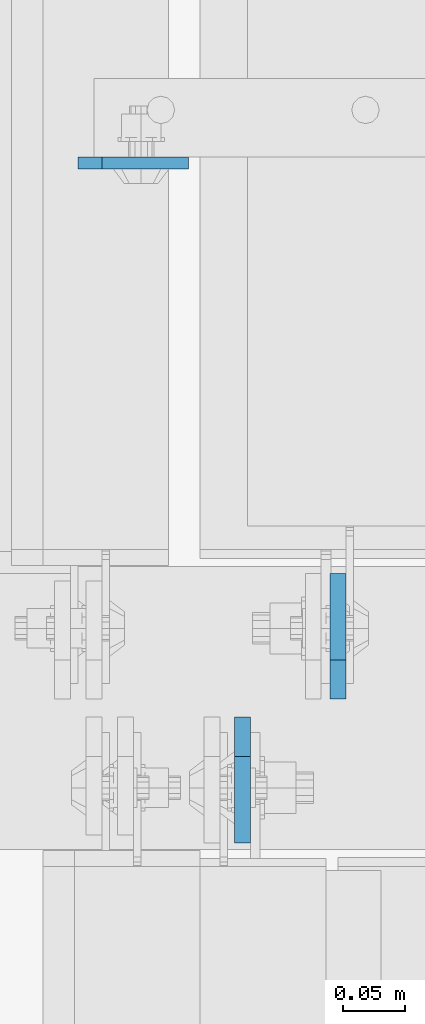
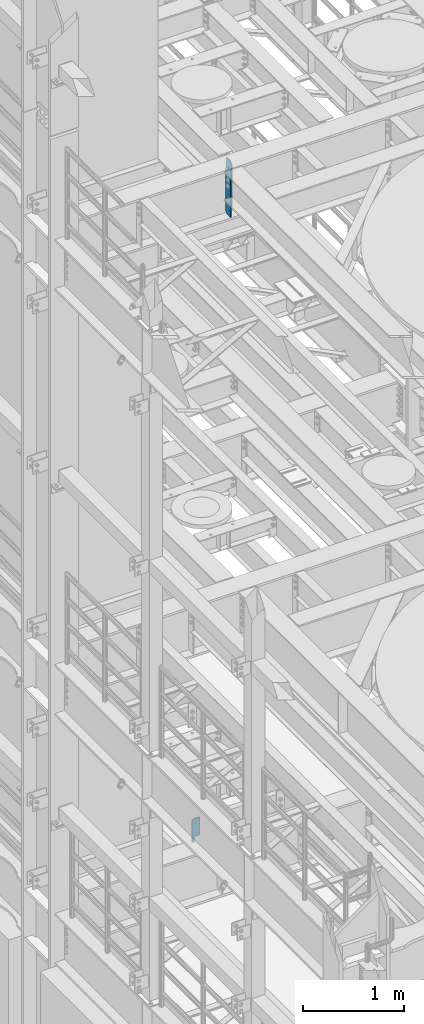
# One storey, part 1560 of 1876: 3 plates, 2 elements without a shape of their own.
"""IFC2X3 building model written with IfcOpenShell, lengths in millimetres."""

from ifc_helpers import new_model, si_unit, frame, origin_with_axes, place, context, subcontext, project, spatial, faceted_brep, material, type_object, element, aggregate, save


model = new_model("IFC2X3")

# Units and contexts
model_context = context("Model", 3, precision=1e-05, world=origin_with_axes())
body_context = subcontext(model_context, "Body", "Model", "MODEL_VIEW")
ifc_project = project(units=[si_unit("LENGTHUNIT", "METRE", prefix="MILLI"), si_unit("AREAUNIT", "SQUARE_METRE"), si_unit("VOLUMEUNIT", "CUBIC_METRE"), si_unit("MASSUNIT", "GRAM", prefix="KILO"), si_unit("TIMEUNIT", "SECOND"), si_unit("PLANEANGLEUNIT", "RADIAN"), si_unit("SOLIDANGLEUNIT", "STERADIAN"), si_unit("THERMODYNAMICTEMPERATUREUNIT", "DEGREE_CELSIUS"), si_unit("LUMINOUSINTENSITYUNIT", "LUMEN")], contexts=[model_context])

# Site, building, storey
site_placement = place(None, origin_with_axes())
site = spatial("IfcSite", under=ifc_project, at=site_placement, CompositionType="ELEMENT")
building_placement = place(site_placement, origin_with_axes())
building = spatial("IfcBuilding", under=site, at=building_placement, Name="Undefined", CompositionType="ELEMENT")
storey_placement = place(building_placement, origin_with_axes())
storey = spatial("IfcBuildingStorey", under=building, at=storey_placement, Name="Undefined", CompositionType="ELEMENT", Elevation=0.0)

# Assembly, plate
assembly_1_placement = place(storey_placement, origin_with_axes())
assembly_1 = element("IfcElementAssembly", 1, at=assembly_1_placement, inside=storey, Name="BEAM", AssemblyPlace="NOTDEFINED", PredefinedType="RIGID_FRAME")
ifc_material = material(Name="STEEL/A36")
plate_type_1 = type_object("IfcPlateType", PredefinedType="NOTDEFINED")
plate_1_placement = place(assembly_1_placement, frame((1882.775, 1963.73659114838, 4833.9375), z_axis=(0.0, 0.0, 1.0), x_axis=(1.0, 0.0, 0.0)))
plate_1 = element("IfcPlate", 2, at=plate_1_placement, type_object=plate_type_1, material=ifc_material, Name="PLATE", context=body_context, shape_type="Brep", body=[
    faceted_brep([(28.5737429031849, -4.76250000000005, 0.0), (28.5737429031849, 4.76250000000005, 0.0), (28.5737429031849, 4.76250000000005, 65.0875016212467), (28.5737429031849, -4.76250000000005, 65.0875016212467), (29.0571078644789, 4.76250000000005, 67.5175413802699), (29.0571078644789, -4.76250000000005, 67.5175413802699), (30.4336148147179, 4.76250000000005, 69.5776296143467), (30.4336148147179, -4.76250000000005, 69.5776296143467), (32.4937030487947, 4.76250000000005, 70.9541365645855), (32.4937030487947, -4.76250000000005, 70.9541365645855), (34.9237428078175, 4.76250000000005, 71.4375015258793), (34.9237428078175, -4.76250000000005, 71.4375015258793), (88.9000283049895, -4.76249999986135, 71.4375), (88.9000015258789, 4.76250000000005, 71.4375), (19.0499992370605, -4.76249999999982, 0.0), (0.0, -4.76249999999982, 19.0499992370605), (0.0, 4.76249999999982, 19.0499992370605), (19.0499992370605, 4.76249999999982, 0.0), (0.0, -4.76249999999982, 271.462512969971), (0.0, 4.76249999999982, 271.462512969971), (19.0499992370605, -4.76249999999982, 290.512512207031), (19.0499992370605, 4.76249999999982, 290.512512207031), (88.9000015258789, -4.76249999999982, 290.512512207031), (88.9000015258789, 4.76249999999982, 290.512512207031)], [[[0, 1, 2, 3]], [[3, 2, 4, 5]], [[5, 4, 6, 7]], [[7, 6, 8, 9]], [[9, 8, 10, 11]], [[12, 11, 10, 13]], [[14, 15, 16, 17]], [[15, 18, 19, 16]], [[18, 20, 21, 19]], [[20, 22, 23, 21]], [[23, 22, 12, 13]], [[8, 6, 4, 2, 1, 17, 16, 19, 21, 23, 13, 10]], [[14, 17, 1, 0]], [[22, 20, 18, 15, 14, 0, 3, 5, 7, 9, 11, 12]]]),
])
aggregate(assembly_1, [plate_1])

# Assembly, plates
assembly_2_placement = place(storey_placement, origin_with_axes())
assembly_2 = element("IfcElementAssembly", 3, at=assembly_2_placement, inside=storey, Name="BEAM", AssemblyPlace="NOTDEFINED", PredefinedType="RIGID_FRAME")
plate_type_2 = type_object("IfcPlateType", PredefinedType="NOTDEFINED")
plate_2_placement = place(assembly_2_placement, frame((2092.32499990463, 1531.14375, 12714.2875), z_axis=(0.0, 0.0, 1.0), x_axis=(0.0, 1.0, 0.0)))
plate_2 = element("IfcPlate", 4, at=plate_2_placement, type_object=plate_type_2, material=ifc_material, Name="PLATE", context=body_context, shape_type="Brep", body=[
    faceted_brep([(0.0, -6.34999999999991, 31.75), (0.0, -6.35000000000036, 538.162475585938), (0.0, 6.35000000000036, 538.162475585938), (0.0, 6.34999999999991, 31.75), (31.75, -6.35000000000036, 569.912475585938), (31.75, 6.35000000000036, 569.912475585938), (101.599998474121, -6.34999999999991, 569.912475585938), (101.599998474121, 6.34999999999991, 569.912475585938), (101.599998474121, -6.35000000000036, 0.0), (101.599998474121, 6.35000000000036, 0.0), (31.75, -6.34999999999991, 0.0), (31.75, 6.34999999999991, 0.0)], [[[0, 1, 2, 3]], [[1, 4, 5, 2]], [[4, 6, 7, 5]], [[6, 8, 9, 7]], [[8, 10, 11, 9]], [[10, 0, 3, 11]], [[5, 7, 9, 11, 3, 2]], [[10, 8, 6, 4, 1, 0]]]),
])
plate_3_placement = place(assembly_2_placement, frame((2015.33153078443, 1516.85625, 12714.2875), z_axis=(0.0, 0.0, 1.0), x_axis=(0.0, -1.0, 0.0)))
plate_3 = element("IfcPlate", 5, at=plate_3_placement, type_object=plate_type_2, material=ifc_material, Name="PLATE", context=body_context, shape_type="Brep", body=[
    faceted_brep([(0.0, -6.34999999999991, 31.75), (0.0, -6.35000000000036, 538.162475585938), (0.0, 6.35000000000036, 538.162475585938), (0.0, 6.34999999999991, 31.75), (31.75, -6.35000000000036, 569.912475585938), (31.75, 6.35000000000036, 569.912475585938), (101.599998474121, -6.34999999999991, 569.912475585938), (101.599998474121, 6.34999999999991, 569.912475585938), (101.599998474121, -6.35000000000036, 0.0), (101.599998474121, 6.35000000000036, 0.0), (31.75, -6.34999999999991, 0.0), (31.75, 6.34999999999991, 0.0)], [[[0, 1, 2, 3]], [[1, 4, 5, 2]], [[4, 6, 7, 5]], [[6, 8, 9, 7]], [[8, 10, 11, 9]], [[10, 0, 3, 11]], [[5, 7, 9, 11, 3, 2]], [[10, 8, 6, 4, 1, 0]]]),
])
aggregate(assembly_2, [plate_2, plate_3])

save(model, "model.ifc")
